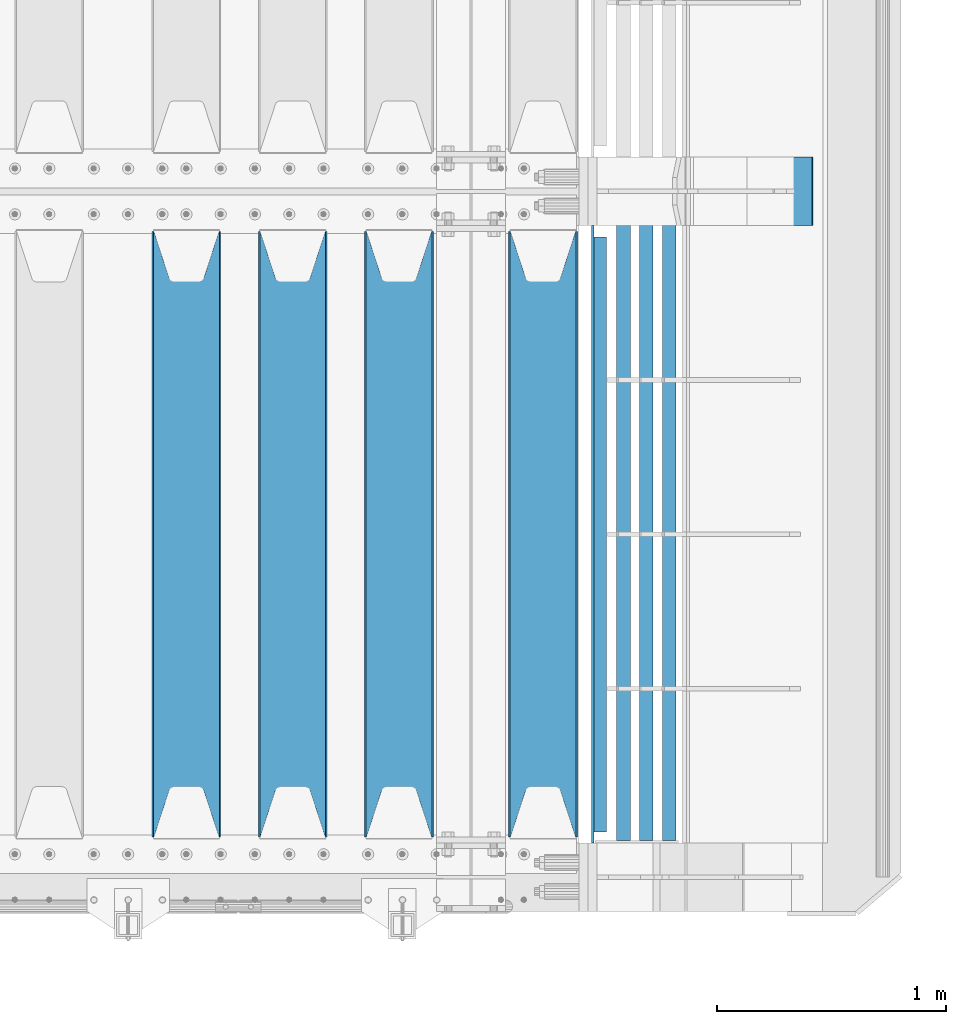
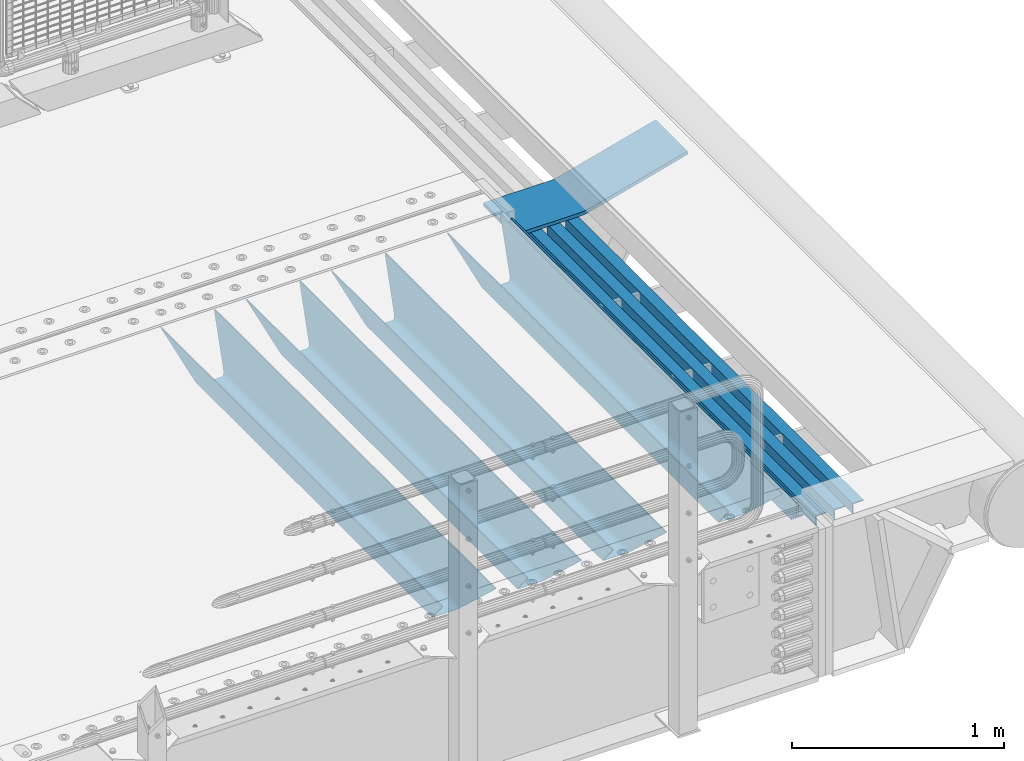
# One storey, part 109 of 208: 9 beams.
"""IFC2X3 building model written with IfcOpenShell, lengths in millimetres."""

from ifc_helpers import new_model, si_unit, frame, origin_with_axes, place, context, subcontext, project, spatial, faceted_brep, material, type_object, element, save


model = new_model("IFC2X3")

# Units and contexts
model_context = context("Model", 3, precision=1e-05, world=origin_with_axes())
body_context = subcontext(model_context, "Body", "Model", "MODEL_VIEW")
ifc_project = project(units=[si_unit("LENGTHUNIT", "METRE", prefix="MILLI"), si_unit("AREAUNIT", "SQUARE_METRE"), si_unit("VOLUMEUNIT", "CUBIC_METRE"), si_unit("MASSUNIT", "GRAM", prefix="KILO"), si_unit("TIMEUNIT", "SECOND"), si_unit("PLANEANGLEUNIT", "RADIAN"), si_unit("SOLIDANGLEUNIT", "STERADIAN"), si_unit("THERMODYNAMICTEMPERATUREUNIT", "DEGREE_CELSIUS"), si_unit("LUMINOUSINTENSITYUNIT", "LUMEN")], contexts=[model_context])

# Site, building, storey
site_placement = place(None, origin_with_axes())
site = spatial("IfcSite", under=ifc_project, at=site_placement, CompositionType="ELEMENT")
building_placement = place(site_placement, origin_with_axes())
building = spatial("IfcBuilding", under=site, at=building_placement, Name="Standard", CompositionType="ELEMENT")
storey_placement = place(building_placement, origin_with_axes())
storey = spatial("IfcBuildingStorey", under=building, at=storey_placement, Name="Undefined", CompositionType="ELEMENT", Elevation=0.0)

# Beams
ifc_material_1 = material(Name="STEEL/S355N")
beam_type_1 = type_object("IfcBeamType", PredefinedType="NOTDEFINED")
beam_1_placement = place(storey_placement, frame((-25790.0, 175.0, -115.0), z_axis=(0.0, 0.0, 1.0), x_axis=(0.0, 1.0, 0.0)))
element("IfcBeam", 1, at=beam_1_placement, inside=storey, type_object=beam_type_1, material=ifc_material_1, context=body_context, shape_type="Brep", body=[
    faceted_brep([(0.0, 150.0, 115.0), (0.0, 143.689999999999, 115.0), (2650.00000000297, 143.689999999999, 115.0), (2650.00000000297, 150.0, 115.0), (2650.00000000297, 142.059565218402, 110.0000000031), (2650.00000000297, 148.369565218403, 110.0000000031), (2441.90079219208, -80.1103600731112, -98.0992078077845), (2437.7588105432, -77.5672621345584, -102.241189456673), (2434.06523489746, -74.4080125315522, -105.934765102404), (2430.91086095089, -70.710272125576, -109.089139048974), (2428.37322971128, -66.5649389910068, -111.626770288588), (2426.51472138055, -62.0739139532889, -113.485278619323), (2425.38102192091, -57.3475956567672, -114.618978078955), (2424.99999999987, -52.5021667386536, -115.0), (2424.99999999987, 52.5021667386536, -115.0), (2425.38102192091, 57.3475956567672, -114.618978078955), (2426.51472138055, 62.0739139532889, -113.485278619323), (2428.37322971128, 66.5649389910068, -111.626770288588), (2430.91086095089, 70.710272125576, -109.089139048974), (2434.06523489746, 74.4080125315522, -105.934765102404), (2437.7588105432, 77.5672621345584, -102.241189456673), (2441.90079219208, 80.1103600731112, -98.0992078077846), (2446.38936140511, 81.9747917625791, -93.6106385947584), (2448.24948500409, 76.2713538057251, -91.7505149957729), (2444.62967112262, 74.76777986261, -95.3703288772456), (2441.28936334126, 72.7168944282894, -98.710636658607), (2438.31067330438, 70.1691124903846, -101.689326695487), (2435.76682334747, 67.1870637758839, -104.233176652398), (2433.72034654133, 63.8440531834895, -106.279653458539), (2432.22154950041, 60.222258798236, -107.778450499454), (2431.30727574265, 56.4107117849089, -108.692724257221), (2430.99999999987, 52.5031078186876, -109.0), (2430.99999999987, -52.5031078186876, -109.0), (2431.30727574265, -56.4107117849089, -108.692724257221), (2432.22154950041, -60.222258798236, -107.778450499454), (2433.72034654133, -63.8440531834895, -106.279653458539), (2435.76682334747, -67.1870637758839, -104.233176652398), (2438.31067330438, -70.1691124903846, -101.689326695487), (2441.28936334126, -72.7168944282894, -98.7106366586071), (2444.62967112262, -74.76777986261, -95.3703288772457), (2448.24948500409, -76.2713538057251, -91.7505149957729), (2650.00000000297, -142.059565218402, 110.0000000031), (2650.00000000297, -148.369565218403, 110.0000000031), (2446.38936140511, -81.9747917625791, -93.6106385947584), (2650.00000000297, -143.689999999999, 115.0), (2650.00000000297, -150.0, 115.0), (0.0, -143.689999999999, 115.0), (0.0, -150.0, 115.0), (0.0, -148.369565218261, 110.000000002663), (203.610638597421, -81.9747917625791, -93.6106385947584), (208.099207810448, -80.1103600731112, -98.0992078077845), (212.241189459336, -77.5672621345584, -102.241189456673), (215.934765105067, -74.4080125315522, -105.934765102404), (219.089139051637, -70.710272125576, -109.089139048974), (221.626770291251, -66.5649389910068, -111.626770288588), (223.485278621986, -62.0739139532889, -113.485278619323), (224.618978081618, -57.3475956567672, -114.618978078955), (225.000000002663, -52.5021667386536, -115.0), (225.000000002663, 52.5021667386536, -115.0), (224.618978081618, 57.3475956567672, -114.618978078955), (223.485278621986, 62.0739139532889, -113.485278619323), (221.626770291251, 66.5649389910068, -111.626770288588), (219.089139051637, 70.710272125576, -109.089139048974), (215.934765105067, 74.4080125315522, -105.934765102404), (212.241189459336, 77.5672621345584, -102.241189456673), (208.099207810448, 80.1103600731112, -98.0992078077846), (203.610638597421, 81.9747917625791, -93.6106385947584), (0.0, 148.369565218261, 110.000000002663), (0.0, 142.05956521826, 110.000000002663), (201.750514998436, 76.2713538057251, -91.7505149957729), (205.370328879908, 74.76777986261, -95.3703288772456), (208.71063666127, 72.7168944282894, -98.710636658607), (211.68932669815, 70.1691124903846, -101.689326695487), (214.233176655061, 67.1870637758839, -104.233176652398), (216.279653461202, 63.8440531834895, -106.279653458539), (217.778450502116, 60.222258798236, -107.778450499454), (218.692724259884, 56.4107117849089, -108.692724257221), (219.000000002663, 52.5031078186876, -109.0), (219.000000002663, -52.5031078186876, -109.0), (218.692724259884, -56.4107117849089, -108.692724257221), (217.778450502116, -60.222258798236, -107.778450499454), (216.279653461202, -63.8440531834895, -106.279653458539), (214.233176655061, -67.1870637758839, -104.233176652398), (211.68932669815, -70.1691124903846, -101.689326695487), (208.71063666127, -72.7168944282894, -98.7106366586071), (205.370328879908, -74.76777986261, -95.3703288772457), (201.750514998436, -76.2713538057251, -91.7505149957729), (0.0, -142.05956521826, 110.000000002663)], [[[0, 1, 2, 3]], [[3, 2, 4, 5]], [[6, 7, 8, 9, 10, 11, 12, 13, 14, 15, 16, 17, 18, 19, 20, 21, 22, 5, 4, 23, 24, 25, 26, 27, 28, 29, 30, 31, 32, 33, 34, 35, 36, 37, 38, 39, 40, 41, 42, 43]], [[44, 45, 42, 41]], [[46, 47, 45, 44]], [[43, 42, 45, 47, 48, 49]], [[6, 43, 49, 50]], [[7, 6, 50, 51]], [[8, 7, 51, 52]], [[9, 8, 52, 53]], [[10, 9, 53, 54]], [[11, 10, 54, 55]], [[12, 11, 55, 56]], [[13, 12, 56, 57]], [[14, 13, 57, 58]], [[15, 14, 58, 59]], [[16, 15, 59, 60]], [[17, 16, 60, 61]], [[18, 17, 61, 62]], [[19, 18, 62, 63]], [[20, 19, 63, 64]], [[21, 20, 64, 65]], [[22, 21, 65, 66]], [[0, 3, 5, 22, 66, 67]], [[1, 0, 67, 68]], [[23, 4, 2, 1, 68, 69]], [[24, 23, 69, 70]], [[25, 24, 70, 71]], [[26, 25, 71, 72]], [[27, 26, 72, 73]], [[28, 27, 73, 74]], [[29, 28, 74, 75]], [[30, 29, 75, 76]], [[31, 30, 76, 77]], [[32, 31, 77, 78]], [[33, 32, 78, 79]], [[34, 33, 79, 80]], [[35, 34, 80, 81]], [[36, 35, 81, 82]], [[37, 36, 82, 83]], [[38, 37, 83, 84]], [[39, 38, 84, 85]], [[40, 39, 85, 86]], [[46, 44, 41, 40, 86, 87]], [[47, 46, 87, 48]], [[86, 85, 84, 83, 82, 81, 80, 79, 78, 77, 76, 75, 74, 73, 72, 71, 70, 69, 68, 67, 66, 65, 64, 63, 62, 61, 60, 59, 58, 57, 56, 55, 54, 53, 52, 51, 50, 49, 48, 87]]]),
])
beam_2_placement = place(storey_placement, frame((-26420.0, 175.0, -115.0), z_axis=(0.0, 0.0, 1.0), x_axis=(0.0, 1.0, 0.0)))
element("IfcBeam", 2, at=beam_2_placement, inside=storey, type_object=beam_type_1, material=ifc_material_1, context=body_context, shape_type="Brep", body=[
    faceted_brep([(0.0, 150.0, 115.0), (0.0, 143.689999999999, 115.0), (2650.00000000297, 143.689999999999, 115.0), (2650.00000000297, 150.0, 115.0), (2650.00000000297, 142.059565218402, 110.0000000031), (2650.00000000297, 148.369565218403, 110.0000000031), (2441.90079219208, -80.1103600731112, -98.0992078077845), (2437.7588105432, -77.5672621345584, -102.241189456673), (2434.06523489746, -74.4080125315522, -105.934765102404), (2430.91086095089, -70.710272125576, -109.089139048974), (2428.37322971128, -66.5649389910068, -111.626770288588), (2426.51472138055, -62.0739139532889, -113.485278619323), (2425.38102192091, -57.3475956567672, -114.618978078955), (2424.99999999987, -52.5021667386536, -115.0), (2424.99999999987, 52.5021667386536, -115.0), (2425.38102192091, 57.3475956567672, -114.618978078955), (2426.51472138055, 62.0739139532889, -113.485278619323), (2428.37322971128, 66.5649389910068, -111.626770288588), (2430.91086095089, 70.710272125576, -109.089139048974), (2434.06523489746, 74.4080125315522, -105.934765102404), (2437.7588105432, 77.5672621345584, -102.241189456673), (2441.90079219208, 80.1103600731112, -98.0992078077846), (2446.38936140511, 81.9747917625791, -93.6106385947584), (2448.24948500409, 76.2713538057251, -91.7505149957729), (2444.62967112262, 74.76777986261, -95.3703288772456), (2441.28936334126, 72.7168944282894, -98.710636658607), (2438.31067330438, 70.1691124903846, -101.689326695487), (2435.76682334747, 67.1870637758839, -104.233176652398), (2433.72034654133, 63.8440531834895, -106.279653458539), (2432.22154950041, 60.222258798236, -107.778450499454), (2431.30727574265, 56.4107117849089, -108.692724257221), (2430.99999999987, 52.5031078186876, -109.0), (2430.99999999987, -52.5031078186876, -109.0), (2431.30727574265, -56.4107117849089, -108.692724257221), (2432.22154950041, -60.222258798236, -107.778450499454), (2433.72034654133, -63.8440531834895, -106.279653458539), (2435.76682334747, -67.1870637758839, -104.233176652398), (2438.31067330438, -70.1691124903846, -101.689326695487), (2441.28936334126, -72.7168944282894, -98.7106366586071), (2444.62967112262, -74.76777986261, -95.3703288772457), (2448.24948500409, -76.2713538057251, -91.7505149957729), (2650.00000000297, -142.059565218402, 110.0000000031), (2650.00000000297, -148.369565218403, 110.0000000031), (2446.38936140511, -81.9747917625791, -93.6106385947584), (2650.00000000297, -143.689999999999, 115.0), (2650.00000000297, -150.0, 115.0), (0.0, -143.689999999999, 115.0), (0.0, -150.0, 115.0), (0.0, -148.369565218261, 110.000000002663), (203.610638597421, -81.9747917625791, -93.6106385947584), (208.099207810448, -80.1103600731112, -98.0992078077845), (212.241189459336, -77.5672621345584, -102.241189456673), (215.934765105067, -74.4080125315522, -105.934765102404), (219.089139051637, -70.710272125576, -109.089139048974), (221.626770291251, -66.5649389910068, -111.626770288588), (223.485278621986, -62.0739139532889, -113.485278619323), (224.618978081618, -57.3475956567672, -114.618978078955), (225.000000002663, -52.5021667386536, -115.0), (225.000000002663, 52.5021667386536, -115.0), (224.618978081618, 57.3475956567672, -114.618978078955), (223.485278621986, 62.0739139532889, -113.485278619323), (221.626770291251, 66.5649389910068, -111.626770288588), (219.089139051637, 70.710272125576, -109.089139048974), (215.934765105067, 74.4080125315522, -105.934765102404), (212.241189459336, 77.5672621345584, -102.241189456673), (208.099207810448, 80.1103600731112, -98.0992078077846), (203.610638597421, 81.9747917625791, -93.6106385947584), (0.0, 148.369565218261, 110.000000002663), (0.0, 142.05956521826, 110.000000002663), (201.750514998436, 76.2713538057251, -91.7505149957729), (205.370328879908, 74.76777986261, -95.3703288772456), (208.71063666127, 72.7168944282894, -98.710636658607), (211.68932669815, 70.1691124903846, -101.689326695487), (214.233176655061, 67.1870637758839, -104.233176652398), (216.279653461202, 63.8440531834895, -106.279653458539), (217.778450502116, 60.222258798236, -107.778450499454), (218.692724259884, 56.4107117849089, -108.692724257221), (219.000000002663, 52.5031078186876, -109.0), (219.000000002663, -52.5031078186876, -109.0), (218.692724259884, -56.4107117849089, -108.692724257221), (217.778450502116, -60.222258798236, -107.778450499454), (216.279653461202, -63.8440531834895, -106.279653458539), (214.233176655061, -67.1870637758839, -104.233176652398), (211.68932669815, -70.1691124903846, -101.689326695487), (208.71063666127, -72.7168944282894, -98.7106366586071), (205.370328879908, -74.76777986261, -95.3703288772457), (201.750514998436, -76.2713538057251, -91.7505149957729), (0.0, -142.05956521826, 110.000000002663)], [[[0, 1, 2, 3]], [[3, 2, 4, 5]], [[6, 7, 8, 9, 10, 11, 12, 13, 14, 15, 16, 17, 18, 19, 20, 21, 22, 5, 4, 23, 24, 25, 26, 27, 28, 29, 30, 31, 32, 33, 34, 35, 36, 37, 38, 39, 40, 41, 42, 43]], [[44, 45, 42, 41]], [[46, 47, 45, 44]], [[43, 42, 45, 47, 48, 49]], [[6, 43, 49, 50]], [[7, 6, 50, 51]], [[8, 7, 51, 52]], [[9, 8, 52, 53]], [[10, 9, 53, 54]], [[11, 10, 54, 55]], [[12, 11, 55, 56]], [[13, 12, 56, 57]], [[14, 13, 57, 58]], [[15, 14, 58, 59]], [[16, 15, 59, 60]], [[17, 16, 60, 61]], [[18, 17, 61, 62]], [[19, 18, 62, 63]], [[20, 19, 63, 64]], [[21, 20, 64, 65]], [[22, 21, 65, 66]], [[0, 3, 5, 22, 66, 67]], [[1, 0, 67, 68]], [[23, 4, 2, 1, 68, 69]], [[24, 23, 69, 70]], [[25, 24, 70, 71]], [[26, 25, 71, 72]], [[27, 26, 72, 73]], [[28, 27, 73, 74]], [[29, 28, 74, 75]], [[30, 29, 75, 76]], [[31, 30, 76, 77]], [[32, 31, 77, 78]], [[33, 32, 78, 79]], [[34, 33, 79, 80]], [[35, 34, 80, 81]], [[36, 35, 81, 82]], [[37, 36, 82, 83]], [[38, 37, 83, 84]], [[39, 38, 84, 85]], [[40, 39, 85, 86]], [[46, 44, 41, 40, 86, 87]], [[47, 46, 87, 48]], [[86, 85, 84, 83, 82, 81, 80, 79, 78, 77, 76, 75, 74, 73, 72, 71, 70, 69, 68, 67, 66, 65, 64, 63, 62, 61, 60, 59, 58, 57, 56, 55, 54, 53, 52, 51, 50, 49, 48, 87]]]),
])
beam_3_placement = place(storey_placement, frame((-26885.0, 175.0, -115.0), z_axis=(0.0, 0.0, 1.0), x_axis=(0.0, 1.0, 0.0)))
element("IfcBeam", 3, at=beam_3_placement, inside=storey, type_object=beam_type_1, material=ifc_material_1, context=body_context, shape_type="Brep", body=[
    faceted_brep([(0.0, 150.0, 115.0), (0.0, 143.689999999999, 115.0), (2650.00000000297, 143.689999999999, 115.0), (2650.00000000297, 150.0, 115.0), (2650.00000000297, 142.059565218402, 110.0000000031), (2650.00000000297, 148.369565218403, 110.0000000031), (2441.90079219208, -80.1103600731112, -98.0992078077845), (2437.7588105432, -77.5672621345584, -102.241189456673), (2434.06523489746, -74.4080125315522, -105.934765102404), (2430.91086095089, -70.710272125576, -109.089139048974), (2428.37322971128, -66.5649389910068, -111.626770288588), (2426.51472138055, -62.0739139532889, -113.485278619323), (2425.38102192091, -57.3475956567672, -114.618978078955), (2424.99999999987, -52.5021667386536, -115.0), (2424.99999999987, 52.5021667386536, -115.0), (2425.38102192091, 57.3475956567672, -114.618978078955), (2426.51472138055, 62.0739139532889, -113.485278619323), (2428.37322971128, 66.5649389910068, -111.626770288588), (2430.91086095089, 70.710272125576, -109.089139048974), (2434.06523489746, 74.4080125315522, -105.934765102404), (2437.7588105432, 77.5672621345584, -102.241189456673), (2441.90079219208, 80.1103600731112, -98.0992078077846), (2446.38936140511, 81.9747917625791, -93.6106385947584), (2448.24948500409, 76.2713538057251, -91.7505149957729), (2444.62967112262, 74.76777986261, -95.3703288772456), (2441.28936334126, 72.7168944282894, -98.710636658607), (2438.31067330438, 70.1691124903846, -101.689326695487), (2435.76682334747, 67.1870637758839, -104.233176652398), (2433.72034654133, 63.8440531834895, -106.279653458539), (2432.22154950041, 60.222258798236, -107.778450499454), (2431.30727574265, 56.4107117849089, -108.692724257221), (2430.99999999987, 52.5031078186876, -109.0), (2430.99999999987, -52.5031078186876, -109.0), (2431.30727574265, -56.4107117849089, -108.692724257221), (2432.22154950041, -60.222258798236, -107.778450499454), (2433.72034654133, -63.8440531834895, -106.279653458539), (2435.76682334747, -67.1870637758839, -104.233176652398), (2438.31067330438, -70.1691124903846, -101.689326695487), (2441.28936334126, -72.7168944282894, -98.7106366586071), (2444.62967112262, -74.76777986261, -95.3703288772457), (2448.24948500409, -76.2713538057251, -91.7505149957729), (2650.00000000297, -142.059565218402, 110.0000000031), (2650.00000000297, -148.369565218403, 110.0000000031), (2446.38936140511, -81.9747917625791, -93.6106385947584), (2650.00000000297, -143.689999999999, 115.0), (2650.00000000297, -150.0, 115.0), (0.0, -143.689999999999, 115.0), (0.0, -150.0, 115.0), (0.0, -148.369565218261, 110.000000002663), (203.610638597421, -81.9747917625791, -93.6106385947584), (208.099207810448, -80.1103600731112, -98.0992078077845), (212.241189459336, -77.5672621345584, -102.241189456673), (215.934765105067, -74.4080125315522, -105.934765102404), (219.089139051637, -70.710272125576, -109.089139048974), (221.626770291251, -66.5649389910068, -111.626770288588), (223.485278621986, -62.0739139532889, -113.485278619323), (224.618978081618, -57.3475956567672, -114.618978078955), (225.000000002663, -52.5021667386536, -115.0), (225.000000002663, 52.5021667386536, -115.0), (224.618978081618, 57.3475956567672, -114.618978078955), (223.485278621986, 62.0739139532889, -113.485278619323), (221.626770291251, 66.5649389910068, -111.626770288588), (219.089139051637, 70.710272125576, -109.089139048974), (215.934765105067, 74.4080125315522, -105.934765102404), (212.241189459336, 77.5672621345584, -102.241189456673), (208.099207810448, 80.1103600731112, -98.0992078077846), (203.610638597421, 81.9747917625791, -93.6106385947584), (0.0, 148.369565218261, 110.000000002663), (0.0, 142.05956521826, 110.000000002663), (201.750514998436, 76.2713538057251, -91.7505149957729), (205.370328879908, 74.76777986261, -95.3703288772456), (208.71063666127, 72.7168944282894, -98.710636658607), (211.68932669815, 70.1691124903846, -101.689326695487), (214.233176655061, 67.1870637758839, -104.233176652398), (216.279653461202, 63.8440531834895, -106.279653458539), (217.778450502116, 60.222258798236, -107.778450499454), (218.692724259884, 56.4107117849089, -108.692724257221), (219.000000002663, 52.5031078186876, -109.0), (219.000000002663, -52.5031078186876, -109.0), (218.692724259884, -56.4107117849089, -108.692724257221), (217.778450502116, -60.222258798236, -107.778450499454), (216.279653461202, -63.8440531834895, -106.279653458539), (214.233176655061, -67.1870637758839, -104.233176652398), (211.68932669815, -70.1691124903846, -101.689326695487), (208.71063666127, -72.7168944282894, -98.7106366586071), (205.370328879908, -74.76777986261, -95.3703288772457), (201.750514998436, -76.2713538057251, -91.7505149957729), (0.0, -142.05956521826, 110.000000002663)], [[[0, 1, 2, 3]], [[3, 2, 4, 5]], [[6, 7, 8, 9, 10, 11, 12, 13, 14, 15, 16, 17, 18, 19, 20, 21, 22, 5, 4, 23, 24, 25, 26, 27, 28, 29, 30, 31, 32, 33, 34, 35, 36, 37, 38, 39, 40, 41, 42, 43]], [[44, 45, 42, 41]], [[46, 47, 45, 44]], [[43, 42, 45, 47, 48, 49]], [[6, 43, 49, 50]], [[7, 6, 50, 51]], [[8, 7, 51, 52]], [[9, 8, 52, 53]], [[10, 9, 53, 54]], [[11, 10, 54, 55]], [[12, 11, 55, 56]], [[13, 12, 56, 57]], [[14, 13, 57, 58]], [[15, 14, 58, 59]], [[16, 15, 59, 60]], [[17, 16, 60, 61]], [[18, 17, 61, 62]], [[19, 18, 62, 63]], [[20, 19, 63, 64]], [[21, 20, 64, 65]], [[22, 21, 65, 66]], [[0, 3, 5, 22, 66, 67]], [[1, 0, 67, 68]], [[23, 4, 2, 1, 68, 69]], [[24, 23, 69, 70]], [[25, 24, 70, 71]], [[26, 25, 71, 72]], [[27, 26, 72, 73]], [[28, 27, 73, 74]], [[29, 28, 74, 75]], [[30, 29, 75, 76]], [[31, 30, 76, 77]], [[32, 31, 77, 78]], [[33, 32, 78, 79]], [[34, 33, 79, 80]], [[35, 34, 80, 81]], [[36, 35, 81, 82]], [[37, 36, 82, 83]], [[38, 37, 83, 84]], [[39, 38, 84, 85]], [[40, 39, 85, 86]], [[46, 44, 41, 40, 86, 87]], [[47, 46, 87, 48]], [[86, 85, 84, 83, 82, 81, 80, 79, 78, 77, 76, 75, 74, 73, 72, 71, 70, 69, 68, 67, 66, 65, 64, 63, 62, 61, 60, 59, 58, 57, 56, 55, 54, 53, 52, 51, 50, 49, 48, 87]]]),
])
beam_4_placement = place(storey_placement, frame((-27350.0, 175.0, -115.0), z_axis=(0.0, 0.0, 1.0), x_axis=(0.0, 1.0, 0.0)))
element("IfcBeam", 4, at=beam_4_placement, inside=storey, type_object=beam_type_1, material=ifc_material_1, context=body_context, shape_type="Brep", body=[
    faceted_brep([(0.0, 150.0, 115.0), (0.0, 143.689999999999, 115.0), (2650.00000000297, 143.689999999999, 115.0), (2650.00000000297, 150.0, 115.0), (2650.00000000297, 142.059565218402, 110.0000000031), (2650.00000000297, 148.369565218403, 110.0000000031), (2441.90079219208, -80.1103600731112, -98.0992078077845), (2437.7588105432, -77.5672621345584, -102.241189456673), (2434.06523489746, -74.4080125315522, -105.934765102404), (2430.91086095089, -70.710272125576, -109.089139048974), (2428.37322971128, -66.5649389910068, -111.626770288588), (2426.51472138055, -62.0739139532889, -113.485278619323), (2425.38102192091, -57.3475956567672, -114.618978078955), (2424.99999999987, -52.5021667386536, -115.0), (2424.99999999987, 52.5021667386536, -115.0), (2425.38102192091, 57.3475956567672, -114.618978078955), (2426.51472138055, 62.0739139532889, -113.485278619323), (2428.37322971128, 66.5649389910068, -111.626770288588), (2430.91086095089, 70.710272125576, -109.089139048974), (2434.06523489746, 74.4080125315522, -105.934765102404), (2437.7588105432, 77.5672621345584, -102.241189456673), (2441.90079219208, 80.1103600731112, -98.0992078077846), (2446.38936140511, 81.9747917625791, -93.6106385947584), (2448.24948500409, 76.2713538057251, -91.7505149957729), (2444.62967112262, 74.76777986261, -95.3703288772456), (2441.28936334126, 72.7168944282894, -98.710636658607), (2438.31067330438, 70.1691124903846, -101.689326695487), (2435.76682334747, 67.1870637758839, -104.233176652398), (2433.72034654133, 63.8440531834895, -106.279653458539), (2432.22154950041, 60.222258798236, -107.778450499454), (2431.30727574265, 56.4107117849089, -108.692724257221), (2430.99999999987, 52.5031078186876, -109.0), (2430.99999999987, -52.5031078186876, -109.0), (2431.30727574265, -56.4107117849089, -108.692724257221), (2432.22154950041, -60.222258798236, -107.778450499454), (2433.72034654133, -63.8440531834895, -106.279653458539), (2435.76682334747, -67.1870637758839, -104.233176652398), (2438.31067330438, -70.1691124903846, -101.689326695487), (2441.28936334126, -72.7168944282894, -98.7106366586071), (2444.62967112262, -74.76777986261, -95.3703288772457), (2448.24948500409, -76.2713538057251, -91.7505149957729), (2650.00000000297, -142.059565218402, 110.0000000031), (2650.00000000297, -148.369565218403, 110.0000000031), (2446.38936140511, -81.9747917625791, -93.6106385947584), (2650.00000000297, -143.689999999999, 115.0), (2650.00000000297, -150.0, 115.0), (0.0, -143.689999999999, 115.0), (0.0, -150.0, 115.0), (0.0, -148.369565218261, 110.000000002663), (203.610638597421, -81.9747917625791, -93.6106385947584), (208.099207810448, -80.1103600731112, -98.0992078077845), (212.241189459336, -77.5672621345584, -102.241189456673), (215.934765105067, -74.4080125315522, -105.934765102404), (219.089139051637, -70.710272125576, -109.089139048974), (221.626770291251, -66.5649389910068, -111.626770288588), (223.485278621986, -62.0739139532889, -113.485278619323), (224.618978081618, -57.3475956567672, -114.618978078955), (225.000000002663, -52.5021667386536, -115.0), (225.000000002663, 52.5021667386536, -115.0), (224.618978081618, 57.3475956567672, -114.618978078955), (223.485278621986, 62.0739139532889, -113.485278619323), (221.626770291251, 66.5649389910068, -111.626770288588), (219.089139051637, 70.710272125576, -109.089139048974), (215.934765105067, 74.4080125315522, -105.934765102404), (212.241189459336, 77.5672621345584, -102.241189456673), (208.099207810448, 80.1103600731112, -98.0992078077846), (203.610638597421, 81.9747917625791, -93.6106385947584), (0.0, 148.369565218261, 110.000000002663), (0.0, 142.05956521826, 110.000000002663), (201.750514998436, 76.2713538057251, -91.7505149957729), (205.370328879908, 74.76777986261, -95.3703288772456), (208.71063666127, 72.7168944282894, -98.710636658607), (211.68932669815, 70.1691124903846, -101.689326695487), (214.233176655061, 67.1870637758839, -104.233176652398), (216.279653461202, 63.8440531834895, -106.279653458539), (217.778450502116, 60.222258798236, -107.778450499454), (218.692724259884, 56.4107117849089, -108.692724257221), (219.000000002663, 52.5031078186876, -109.0), (219.000000002663, -52.5031078186876, -109.0), (218.692724259884, -56.4107117849089, -108.692724257221), (217.778450502116, -60.222258798236, -107.778450499454), (216.279653461202, -63.8440531834895, -106.279653458539), (214.233176655061, -67.1870637758839, -104.233176652398), (211.68932669815, -70.1691124903846, -101.689326695487), (208.71063666127, -72.7168944282894, -98.7106366586071), (205.370328879908, -74.76777986261, -95.3703288772457), (201.750514998436, -76.2713538057251, -91.7505149957729), (0.0, -142.05956521826, 110.000000002663)], [[[0, 1, 2, 3]], [[3, 2, 4, 5]], [[6, 7, 8, 9, 10, 11, 12, 13, 14, 15, 16, 17, 18, 19, 20, 21, 22, 5, 4, 23, 24, 25, 26, 27, 28, 29, 30, 31, 32, 33, 34, 35, 36, 37, 38, 39, 40, 41, 42, 43]], [[44, 45, 42, 41]], [[46, 47, 45, 44]], [[43, 42, 45, 47, 48, 49]], [[6, 43, 49, 50]], [[7, 6, 50, 51]], [[8, 7, 51, 52]], [[9, 8, 52, 53]], [[10, 9, 53, 54]], [[11, 10, 54, 55]], [[12, 11, 55, 56]], [[13, 12, 56, 57]], [[14, 13, 57, 58]], [[15, 14, 58, 59]], [[16, 15, 59, 60]], [[17, 16, 60, 61]], [[18, 17, 61, 62]], [[19, 18, 62, 63]], [[20, 19, 63, 64]], [[21, 20, 64, 65]], [[22, 21, 65, 66]], [[0, 3, 5, 22, 66, 67]], [[1, 0, 67, 68]], [[23, 4, 2, 1, 68, 69]], [[24, 23, 69, 70]], [[25, 24, 70, 71]], [[26, 25, 71, 72]], [[27, 26, 72, 73]], [[28, 27, 73, 74]], [[29, 28, 74, 75]], [[30, 29, 75, 76]], [[31, 30, 76, 77]], [[32, 31, 77, 78]], [[33, 32, 78, 79]], [[34, 33, 79, 80]], [[35, 34, 80, 81]], [[36, 35, 81, 82]], [[37, 36, 82, 83]], [[38, 37, 83, 84]], [[39, 38, 84, 85]], [[40, 39, 85, 86]], [[46, 44, 41, 40, 86, 87]], [[47, 46, 87, 48]], [[86, 85, 84, 83, 82, 81, 80, 79, 78, 77, 76, 75, 74, 73, 72, 71, 70, 69, 68, 67, 66, 65, 64, 63, 62, 61, 60, 59, 58, 57, 56, 55, 54, 53, 52, 51, 50, 49, 48, 87]]]),
])
ifc_material_2 = material(Name="STEEL/S355J2")
beam_type_2 = type_object("IfcBeamType", PredefinedType="NOTDEFINED")
beam_5_placement = place(storey_placement, frame((-25545.4974739935, 150.0, -124.999999999985), z_axis=(0.0, 0.0, 1.0), x_axis=(0.0, 1.0, 0.0)))
element("IfcBeam", 5, at=beam_5_placement, inside=storey, type_object=beam_type_2, material=ifc_material_2, context=body_context, shape_type="Brep", body=[
    faceted_brep([(2700.0, 22.5, -15.0), (2684.54915028125, 22.5000000000036, -17.4471741852423), (2684.54915028125, 32.5000000000036, -17.4471741852423), (2700.0, 32.5, -15.0), (2670.61073738538, 22.5000000000036, -24.5491502812526), (2670.61073738538, 32.5000000000036, -24.5491502812526), (2659.54915028125, 22.5000000000036, -35.6107373853764), (2659.54915028125, 32.5000000000036, -35.6107373853764), (2652.44717418524, 22.5000000000036, -49.5491502812526), (2652.44717418524, 32.5000000000036, -49.5491502812526), (2651.58384440324, -32.5, -55.0), (2650.0, -32.5, -65.0), (2650.0, 32.5, -65.0), (2651.58384440324, 22.5, -55.0), (0.0, 32.5, 65.0), (0.0, 22.5, 65.0), (2700.0, 22.5, 65.0), (2700.0, 32.5, 65.0), (0.0, 32.5, -15.0), (0.0, 22.5, -15.0), (15.4508497187474, 32.5, -17.4471741852423), (15.4508497187474, 22.5, -17.4471741852423), (29.3892626146236, 32.5, -24.5491502812526), (29.3892626146236, 22.5, -24.5491502812526), (40.4508497187473, 32.5, -35.6107373853764), (40.4508497187473, 22.5, -35.6107373853764), (47.5528258147577, 32.5, -49.5491502812526), (47.5528258147577, 22.5, -49.5491502812526), (50.0, -32.5, -65.0), (48.4161555967548, -32.5, -55.0), (48.4161555967548, 22.5, -55.0), (50.0, 32.5, -65.0)], [[[0, 1, 2, 3]], [[4, 5, 2, 1]], [[6, 7, 5, 4]], [[8, 9, 7, 6]], [[10, 11, 12, 9, 8, 13]], [[14, 15, 16, 17]], [[15, 14, 18, 19]], [[19, 18, 20, 21]], [[21, 20, 22, 23]], [[23, 22, 24, 25]], [[25, 24, 26, 27]], [[28, 29, 30, 27, 26, 31]], [[30, 29, 10, 13]], [[16, 15, 19, 21, 23, 25, 27, 30, 13, 8, 6, 4, 1, 0]], [[17, 16, 0, 3]], [[5, 7, 9, 12, 31, 26, 24, 22, 20, 18, 14, 17, 3, 2]], [[28, 31, 12, 11]], [[29, 28, 11, 10]]]),
])
beam_type_3 = type_object("IfcBeamType", PredefinedType="NOTDEFINED")
for number, where, z_axis, x_axis in (
    (6, (-25237.9975852833, 2869.99999765913, -210.000211453654), (0.0, 0.0, -1.0), (0.0, -1.0, 0.0)),
    (7, (-25337.9975852833, 2869.99999765913, -210.000211453654), (0.0, 0.0, -1.0), (0.0, -1.0, 0.0)),
    (8, (-25437.997585284, 2869.99999765913, -210.000211453713), (0.0, 0.0, -1.0), (0.0, -1.0, 0.0)),
):
    element("IfcBeam", number, at=place(storey_placement, frame(where, z_axis=z_axis, x_axis=x_axis)), inside=storey, type_object=beam_type_3, material=ifc_material_2, context=body_context, shape_type="Brep", body=[
        faceted_brep([(4.54747350886464e-13, 30.0000000000036, -30.0), (4.54747350886464e-13, 30.0000000000036, 30.0000000000001), (2710.00000000001, 30.0000000000036, 30.0000000000001), (2710.00000000001, 30.0000000000036, -30.0), (4.54747350886464e-13, 24.0000000000036, 30.0), (2710.00000000001, 24.0000000000036, 30.0), (4.54747350886464e-13, 24.0000000000036, -24.0), (2710.00000000001, 24.0000000000036, -24.0), (4.54747350886464e-13, -29.9999999999964, -24.0), (2710.00000000001, -29.9999999999964, -24.0), (4.54747350886464e-13, -29.9999999999964, -30.0), (2710.00000000001, -29.9999999999964, -30.0)], [[[0, 1, 2, 3]], [[1, 4, 5, 2]], [[4, 6, 7, 5]], [[6, 8, 9, 7]], [[8, 10, 11, 9]], [[10, 0, 3, 11]], [[5, 7, 9, 11, 3, 2]], [[10, 8, 6, 4, 1, 0]]]),
    ])
beam_type_4 = type_object("IfcBeamType", PredefinedType="NOTDEFINED")
beam_6_placement = place(storey_placement, frame((-25553.0011701094, 3000.0, -169.999999999995), z_axis=(0.0, -1.0, 0.0), x_axis=(1.0, 0.0, 0.0)))
element("IfcBeam", 9, at=beam_6_placement, inside=storey, type_object=beam_type_4, material=ifc_material_1, context=body_context, shape_type="Brep", body=[
    faceted_brep([(0.0, 10.0, -150.0), (0.0, 10.0, 150.0), (356.495387467741, 10.0, 150.0), (356.495387467749, 9.99999999999858, -150.0), (0.0, -10.0, 150.0), (0.0, -10.0, -150.0), (356.495387467741, -10.0, -150.0), (356.495387467741, -10.0, 150.0), (382.770279632416, 11.7334369044538, 150.0), (382.770279632416, 11.7334369044538, -150.0), (385.397768848896, -8.09321940509972, -150.0), (385.397768848896, -8.09321940509972, 150.0), (413.799145684919, -2.40593045895696, -150.0), (413.799145684919, -2.40593045895696, 150.0), (408.589713119687, 16.9036995827633, 150.0), (408.589713119891, 16.9036995827009, -150.0), (939.000000000015, 160.0, 150.0), (939.000000000015, 160.0, -150.0), (944.209432565229, 140.69036995827, 150.0), (944.209432565229, 140.69036995827, -150.0)], [[[0, 1, 2, 3]], [[4, 5, 6, 7]], [[5, 4, 1, 0]], [[3, 2, 8, 9]], [[7, 6, 10, 11]], [[10, 12, 13, 11]], [[8, 14, 15, 9]], [[15, 14, 16, 17]], [[14, 8, 2, 1, 4, 7, 11, 13, 18, 16]], [[13, 12, 19, 18]], [[12, 10, 6, 5, 0, 3, 9, 15, 17, 19]], [[18, 19, 17, 16]]]),
])

save(model, "model.ifc")
